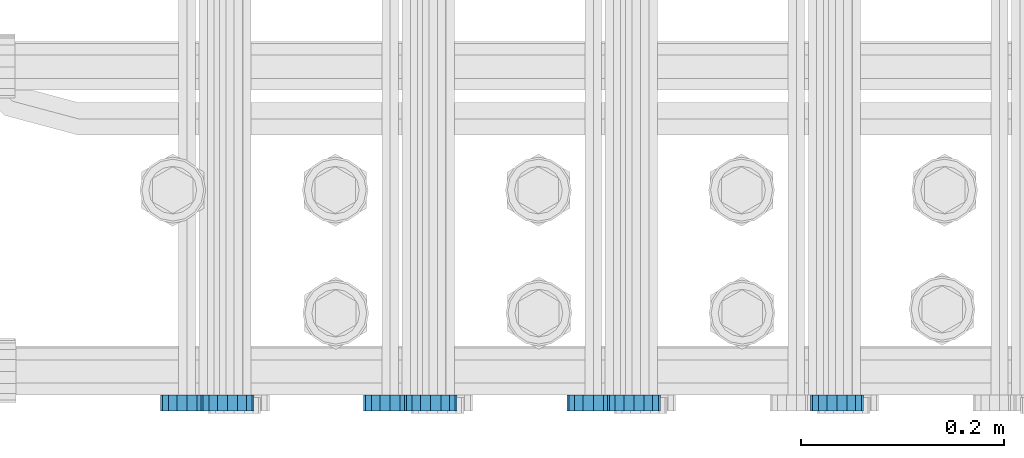
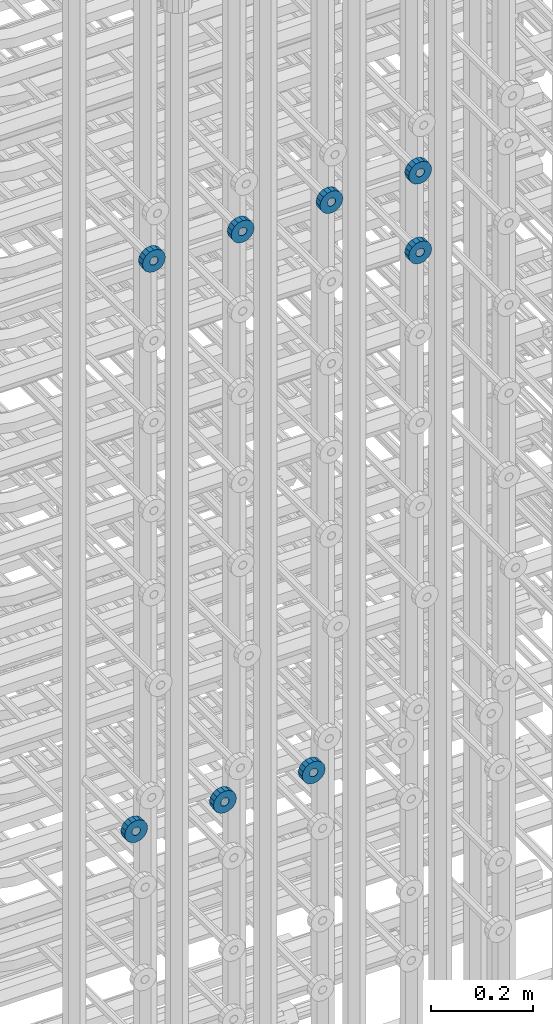
# One storey, part 116 of 177: 8 beams.
"""IFC2X3 building model written with IfcOpenShell, lengths in millimetres."""

from ifc_helpers import new_model, si_unit, frame, origin_with_axes, place, context, subcontext, project, spatial, faceted_brep, material, type_object, element, save


model = new_model("IFC2X3")

# Units and contexts
model_context_1 = context("Model", 3, precision=1e-05, world=origin_with_axes())
model_context_2 = context("Model", 3, precision=1e-05, world=origin_with_axes())
body_context = subcontext(model_context_2, "Body", "Model", "MODEL_VIEW")
ifc_project = project(units=[si_unit("LENGTHUNIT", "METRE", prefix="MILLI"), si_unit("AREAUNIT", "SQUARE_METRE"), si_unit("VOLUMEUNIT", "CUBIC_METRE"), si_unit("MASSUNIT", "GRAM", prefix="KILO"), si_unit("TIMEUNIT", "SECOND"), si_unit("PLANEANGLEUNIT", "RADIAN"), si_unit("SOLIDANGLEUNIT", "STERADIAN"), si_unit("THERMODYNAMICTEMPERATUREUNIT", "DEGREE_CELSIUS"), si_unit("LUMINOUSINTENSITYUNIT", "LUMEN")], contexts=[model_context_1])

# Site, building, storey
site_placement = place(None, origin_with_axes())
site = spatial("IfcSite", under=ifc_project, at=site_placement, CompositionType="ELEMENT")
building_placement = place(site_placement, origin_with_axes())
building = spatial("IfcBuilding", under=site, at=building_placement, Name="Undefined", CompositionType="ELEMENT")
storey_placement = place(building_placement, origin_with_axes())
storey = spatial("IfcBuildingStorey", under=building, at=storey_placement, Name="Undefined", CompositionType="ELEMENT", Elevation=0.0)

# Beams
ifc_material = material(Name="STEEL/Steel_Undefined")
beam_type = type_object("IfcBeamType", PredefinedType="NOTDEFINED")
beam_1_placement = place(storey_placement, frame((2030489.49847313, 6205075.98588033, 20799.986811442), z_axis=(0.0, 0.0, -1.0), x_axis=(0.0, -1.0, 0.0)))
element("IfcBeam", 1, at=beam_1_placement, inside=storey, type_object=beam_type, material=ifc_material, context=body_context, shape_type="Brep", body=[
    faceted_brep([(0.0, -9.5, 0.0), (0.0, -8.77685555908829, 3.63549260746731), (16.0, -8.77685555908829, 3.63549260746731), (16.0, -9.5, 0.0), (0.0, -6.71751442085952, 6.71751442127061), (16.0, -6.71751442085952, 6.71751442127061), (0.0, -3.63549260701984, 8.77685555885546), (16.0, -3.63549260701984, 8.77685555885546), (-2.02452244836415e-12, 0.0, 9.5), (16.0, 0.0, 9.5), (0.0, 3.63549260701984, 8.77685555885546), (16.0, 3.63549260701984, 8.77685555885546), (0.0, 6.71751442085952, 6.71751442127061), (16.0, 6.71751442085952, 6.71751442127061), (0.0, 8.77685555908829, 3.63549260746731), (16.0, 8.77685555908829, 3.63549260746731), (0.0, 9.5, 0.0), (16.0, 9.5, 0.0), (0.0, 8.77685555908829, -3.63549260746731), (16.0, 8.77685555908829, -3.63549260746731), (0.0, 6.71751442085952, -6.71751442127061), (16.0, 6.71751442085952, -6.71751442127061), (0.0, 3.63549260701984, -8.77685555885546), (16.0, 3.63549260701984, -8.77685555885546), (2.02452244836415e-12, -3.69149155687865e-15, -9.5), (16.0, 0.0, -9.5), (0.0, -3.63549260701984, -8.77685555885546), (16.0, -3.63549260701984, -8.77685555885546), (0.0, -6.71751442085952, -6.71751442127061), (16.0, -6.71751442085952, -6.71751442127061), (0.0, -8.77685555908829, -3.63549260746731), (16.0, -8.77685555908829, -3.63549260746731), (0.0, -26.0, 0.0), (0.0, -24.0208678450435, -9.94976924149159), (16.0, -24.0208678450435, -9.94976924149159), (16.0, -26.0, 0.0), (0.0, -18.3847763109952, -18.3847763108497), (16.0, -18.3847763109952, -18.3847763108497), (0.0, -9.94976924173534, -24.0208678452946), (16.0, -9.94976924173534, -24.0208678452946), (0.0, 0.0, -26.0), (16.0, 0.0, -26.0), (0.0, 9.94976924173534, -24.0208678452946), (16.0, 9.94976924173534, -24.0208678452946), (0.0, 18.3847763109952, -18.3847763108497), (16.0, 18.3847763109952, -18.3847763108497), (0.0, 24.0208678450435, -9.94976924149159), (16.0, 24.0208678450435, -9.94976924149159), (0.0, 26.0, 0.0), (16.0, 26.0, 0.0), (0.0, 24.0208678450435, 9.94976924149159), (16.0, 24.0208678450435, 9.94976924149159), (0.0, 18.3847763109952, 18.3847763108497), (16.0, 18.3847763109952, 18.3847763108497), (0.0, 9.94976924173534, 24.0208678452946), (16.0, 9.94976924173534, 24.0208678452946), (0.0, 0.0, 26.0), (16.0, 0.0, 26.0), (0.0, -9.94976924173534, 24.0208678452946), (16.0, -9.94976924173534, 24.0208678452946), (0.0, -18.3847763109952, 18.3847763108497), (16.0, -18.3847763109952, 18.3847763108497), (0.0, -24.0208678450435, 9.94976924149159), (16.0, -24.0208678450435, 9.94976924149159)], [[[0, 1, 2, 3]], [[1, 4, 5, 2]], [[4, 6, 7, 5]], [[6, 8, 9, 7]], [[8, 10, 11, 9]], [[10, 12, 13, 11]], [[12, 14, 15, 13]], [[14, 16, 17, 15]], [[16, 18, 19, 17]], [[18, 20, 21, 19]], [[20, 22, 23, 21]], [[22, 24, 25, 23]], [[24, 26, 27, 25]], [[26, 28, 29, 27]], [[28, 30, 31, 29]], [[30, 0, 3, 31]], [[32, 33, 34, 35]], [[33, 36, 37, 34]], [[36, 38, 39, 37]], [[38, 40, 41, 39]], [[40, 42, 43, 41]], [[42, 44, 45, 43]], [[44, 46, 47, 45]], [[46, 48, 49, 47]], [[48, 50, 51, 49]], [[50, 52, 53, 51]], [[52, 54, 55, 53]], [[54, 56, 57, 55]], [[56, 58, 59, 57]], [[58, 60, 61, 59]], [[60, 62, 63, 61]], [[62, 32, 35, 63]], [[37, 39, 41, 43, 45, 47, 49, 51, 53, 55, 57, 59, 61, 63, 35, 34], [5, 7, 9, 11, 13, 15, 17, 19, 21, 23, 25, 27, 29, 31, 3, 2]], [[62, 60, 58, 56, 54, 52, 50, 48, 46, 44, 42, 40, 38, 36, 33, 32], [30, 28, 26, 24, 22, 20, 18, 16, 14, 12, 10, 8, 6, 4, 1, 0]]]),
])
beam_2_placement = place(storey_placement, frame((2030289.49847313, 6205075.98588033, 20799.986811442), z_axis=(0.0, 0.0, -1.0), x_axis=(0.0, -1.0, 0.0)))
element("IfcBeam", 2, at=beam_2_placement, inside=storey, type_object=beam_type, material=ifc_material, context=body_context, shape_type="Brep", body=[
    faceted_brep([(0.0, -9.5, 0.0), (0.0, -8.77685555908829, 3.63549260746731), (16.0, -8.77685555908829, 3.63549260746731), (16.0, -9.5, 0.0), (0.0, -6.71751442085952, 6.71751442127061), (16.0, -6.71751442085952, 6.71751442127061), (0.0, -3.63549260701984, 8.77685555885546), (16.0, -3.63549260701984, 8.77685555885546), (-2.02452244836415e-12, 0.0, 9.5), (16.0, 0.0, 9.5), (0.0, 3.63549260701984, 8.77685555885546), (16.0, 3.63549260701984, 8.77685555885546), (0.0, 6.71751442085952, 6.71751442127061), (16.0, 6.71751442085952, 6.71751442127061), (0.0, 8.77685555908829, 3.63549260746731), (16.0, 8.77685555908829, 3.63549260746731), (0.0, 9.5, 0.0), (16.0, 9.5, 0.0), (0.0, 8.77685555908829, -3.63549260746731), (16.0, 8.77685555908829, -3.63549260746731), (0.0, 6.71751442085952, -6.71751442127061), (16.0, 6.71751442085952, -6.71751442127061), (0.0, 3.63549260701984, -8.77685555885546), (16.0, 3.63549260701984, -8.77685555885546), (2.02452244836415e-12, -3.69149155687865e-15, -9.5), (16.0, 0.0, -9.5), (0.0, -3.63549260701984, -8.77685555885546), (16.0, -3.63549260701984, -8.77685555885546), (0.0, -6.71751442085952, -6.71751442127061), (16.0, -6.71751442085952, -6.71751442127061), (0.0, -8.77685555908829, -3.63549260746731), (16.0, -8.77685555908829, -3.63549260746731), (0.0, -26.0, 0.0), (0.0, -24.0208678450435, -9.94976924149159), (16.0, -24.0208678450435, -9.94976924149159), (16.0, -26.0, 0.0), (0.0, -18.3847763109952, -18.3847763108497), (16.0, -18.3847763109952, -18.3847763108497), (0.0, -9.94976924173534, -24.0208678452946), (16.0, -9.94976924173534, -24.0208678452946), (0.0, 0.0, -26.0), (16.0, 0.0, -26.0), (0.0, 9.94976924173534, -24.0208678452946), (16.0, 9.94976924173534, -24.0208678452946), (0.0, 18.3847763109952, -18.3847763108497), (16.0, 18.3847763109952, -18.3847763108497), (0.0, 24.0208678450435, -9.94976924149159), (16.0, 24.0208678450435, -9.94976924149159), (0.0, 26.0, 0.0), (16.0, 26.0, 0.0), (0.0, 24.0208678450435, 9.94976924149159), (16.0, 24.0208678450435, 9.94976924149159), (0.0, 18.3847763109952, 18.3847763108497), (16.0, 18.3847763109952, 18.3847763108497), (0.0, 9.94976924173534, 24.0208678452946), (16.0, 9.94976924173534, 24.0208678452946), (0.0, 0.0, 26.0), (16.0, 0.0, 26.0), (0.0, -9.94976924173534, 24.0208678452946), (16.0, -9.94976924173534, 24.0208678452946), (0.0, -18.3847763109952, 18.3847763108497), (16.0, -18.3847763109952, 18.3847763108497), (0.0, -24.0208678450435, 9.94976924149159), (16.0, -24.0208678450435, 9.94976924149159)], [[[0, 1, 2, 3]], [[1, 4, 5, 2]], [[4, 6, 7, 5]], [[6, 8, 9, 7]], [[8, 10, 11, 9]], [[10, 12, 13, 11]], [[12, 14, 15, 13]], [[14, 16, 17, 15]], [[16, 18, 19, 17]], [[18, 20, 21, 19]], [[20, 22, 23, 21]], [[22, 24, 25, 23]], [[24, 26, 27, 25]], [[26, 28, 29, 27]], [[28, 30, 31, 29]], [[30, 0, 3, 31]], [[32, 33, 34, 35]], [[33, 36, 37, 34]], [[36, 38, 39, 37]], [[38, 40, 41, 39]], [[40, 42, 43, 41]], [[42, 44, 45, 43]], [[44, 46, 47, 45]], [[46, 48, 49, 47]], [[48, 50, 51, 49]], [[50, 52, 53, 51]], [[52, 54, 55, 53]], [[54, 56, 57, 55]], [[56, 58, 59, 57]], [[58, 60, 61, 59]], [[60, 62, 63, 61]], [[62, 32, 35, 63]], [[37, 39, 41, 43, 45, 47, 49, 51, 53, 55, 57, 59, 61, 63, 35, 34], [5, 7, 9, 11, 13, 15, 17, 19, 21, 23, 25, 27, 29, 31, 3, 2]], [[62, 60, 58, 56, 54, 52, 50, 48, 46, 44, 42, 40, 38, 36, 33, 32], [30, 28, 26, 24, 22, 20, 18, 16, 14, 12, 10, 8, 6, 4, 1, 0]]]),
])
beam_3_placement = place(storey_placement, frame((2030089.49847313, 6205075.98588033, 20799.986811442), z_axis=(0.0, 0.0, -1.0), x_axis=(0.0, -1.0, 0.0)))
element("IfcBeam", 3, at=beam_3_placement, inside=storey, type_object=beam_type, material=ifc_material, context=body_context, shape_type="Brep", body=[
    faceted_brep([(0.0, -9.5, 0.0), (0.0, -8.77685555908829, 3.63549260746731), (16.0, -8.77685555908829, 3.63549260746731), (16.0, -9.5, 0.0), (0.0, -6.71751442085952, 6.71751442127061), (16.0, -6.71751442085952, 6.71751442127061), (0.0, -3.63549260701984, 8.77685555885546), (16.0, -3.63549260701984, 8.77685555885546), (-2.02452244836415e-12, 0.0, 9.5), (16.0, 0.0, 9.5), (0.0, 3.63549260701984, 8.77685555885546), (16.0, 3.63549260701984, 8.77685555885546), (0.0, 6.71751442085952, 6.71751442127061), (16.0, 6.71751442085952, 6.71751442127061), (0.0, 8.77685555908829, 3.63549260746731), (16.0, 8.77685555908829, 3.63549260746731), (0.0, 9.5, 0.0), (16.0, 9.5, 0.0), (0.0, 8.77685555908829, -3.63549260746731), (16.0, 8.77685555908829, -3.63549260746731), (0.0, 6.71751442085952, -6.71751442127061), (16.0, 6.71751442085952, -6.71751442127061), (0.0, 3.63549260701984, -8.77685555885546), (16.0, 3.63549260701984, -8.77685555885546), (2.02452244836415e-12, -3.69149155687865e-15, -9.5), (16.0, 0.0, -9.5), (0.0, -3.63549260701984, -8.77685555885546), (16.0, -3.63549260701984, -8.77685555885546), (0.0, -6.71751442085952, -6.71751442127061), (16.0, -6.71751442085952, -6.71751442127061), (0.0, -8.77685555908829, -3.63549260746731), (16.0, -8.77685555908829, -3.63549260746731), (0.0, -26.0, 0.0), (0.0, -24.0208678450435, -9.94976924149159), (16.0, -24.0208678450435, -9.94976924149159), (16.0, -26.0, 0.0), (0.0, -18.3847763109952, -18.3847763108497), (16.0, -18.3847763109952, -18.3847763108497), (0.0, -9.94976924173534, -24.0208678452946), (16.0, -9.94976924173534, -24.0208678452946), (0.0, 0.0, -26.0), (16.0, 0.0, -26.0), (0.0, 9.94976924173534, -24.0208678452946), (16.0, 9.94976924173534, -24.0208678452946), (0.0, 18.3847763109952, -18.3847763108497), (16.0, 18.3847763109952, -18.3847763108497), (0.0, 24.0208678450435, -9.94976924149159), (16.0, 24.0208678450435, -9.94976924149159), (0.0, 26.0, 0.0), (16.0, 26.0, 0.0), (0.0, 24.0208678450435, 9.94976924149159), (16.0, 24.0208678450435, 9.94976924149159), (0.0, 18.3847763109952, 18.3847763108497), (16.0, 18.3847763109952, 18.3847763108497), (0.0, 9.94976924173534, 24.0208678452946), (16.0, 9.94976924173534, 24.0208678452946), (0.0, 0.0, 26.0), (16.0, 0.0, 26.0), (0.0, -9.94976924173534, 24.0208678452946), (16.0, -9.94976924173534, 24.0208678452946), (0.0, -18.3847763109952, 18.3847763108497), (16.0, -18.3847763109952, 18.3847763108497), (0.0, -24.0208678450435, 9.94976924149159), (16.0, -24.0208678450435, 9.94976924149159)], [[[0, 1, 2, 3]], [[1, 4, 5, 2]], [[4, 6, 7, 5]], [[6, 8, 9, 7]], [[8, 10, 11, 9]], [[10, 12, 13, 11]], [[12, 14, 15, 13]], [[14, 16, 17, 15]], [[16, 18, 19, 17]], [[18, 20, 21, 19]], [[20, 22, 23, 21]], [[22, 24, 25, 23]], [[24, 26, 27, 25]], [[26, 28, 29, 27]], [[28, 30, 31, 29]], [[30, 0, 3, 31]], [[32, 33, 34, 35]], [[33, 36, 37, 34]], [[36, 38, 39, 37]], [[38, 40, 41, 39]], [[40, 42, 43, 41]], [[42, 44, 45, 43]], [[44, 46, 47, 45]], [[46, 48, 49, 47]], [[48, 50, 51, 49]], [[50, 52, 53, 51]], [[52, 54, 55, 53]], [[54, 56, 57, 55]], [[56, 58, 59, 57]], [[58, 60, 61, 59]], [[60, 62, 63, 61]], [[62, 32, 35, 63]], [[37, 39, 41, 43, 45, 47, 49, 51, 53, 55, 57, 59, 61, 63, 35, 34], [5, 7, 9, 11, 13, 15, 17, 19, 21, 23, 25, 27, 29, 31, 3, 2]], [[62, 60, 58, 56, 54, 52, 50, 48, 46, 44, 42, 40, 38, 36, 33, 32], [30, 28, 26, 24, 22, 20, 18, 16, 14, 12, 10, 8, 6, 4, 1, 0]]]),
])
beam_4_placement = place(storey_placement, frame((2030729.49847313, 6205075.98588636, 22144.9868126721), z_axis=(0.0, 0.0, -1.0), x_axis=(0.0, -1.0, 0.0)))
element("IfcBeam", 4, at=beam_4_placement, inside=storey, type_object=beam_type, material=ifc_material, context=body_context, shape_type="Brep", body=[
    faceted_brep([(0.0, -9.5, 0.0), (0.0, -8.77685555908829, 3.63549260746731), (16.0, -8.77685555908829, 3.63549260746731), (16.0, -9.5, 0.0), (0.0, -6.71751442085952, 6.71751442127061), (16.0, -6.71751442085952, 6.71751442127061), (0.0, -3.63549260701984, 8.77685555885546), (16.0, -3.63549260701984, 8.77685555885546), (-2.02452244836415e-12, 0.0, 9.5), (16.0, 0.0, 9.5), (0.0, 3.63549260701984, 8.77685555885546), (16.0, 3.63549260701984, 8.77685555885546), (0.0, 6.71751442085952, 6.71751442127061), (16.0, 6.71751442085952, 6.71751442127061), (0.0, 8.77685555908829, 3.63549260746731), (16.0, 8.77685555908829, 3.63549260746731), (0.0, 9.5, 0.0), (16.0, 9.5, 0.0), (0.0, 8.77685555908829, -3.63549260746731), (16.0, 8.77685555908829, -3.63549260746731), (0.0, 6.71751442085952, -6.71751442127061), (16.0, 6.71751442085952, -6.71751442127061), (0.0, 3.63549260701984, -8.77685555885546), (16.0, 3.63549260701984, -8.77685555885546), (2.02452244836415e-12, -3.69149155687865e-15, -9.5), (16.0, 0.0, -9.5), (0.0, -3.63549260701984, -8.77685555885546), (16.0, -3.63549260701984, -8.77685555885546), (0.0, -6.71751442085952, -6.71751442127061), (16.0, -6.71751442085952, -6.71751442127061), (0.0, -8.77685555908829, -3.63549260746731), (16.0, -8.77685555908829, -3.63549260746731), (0.0, -26.0, 0.0), (0.0, -24.0208678450435, -9.94976924149159), (16.0, -24.0208678450435, -9.94976924149159), (16.0, -26.0, 0.0), (0.0, -18.3847763109952, -18.3847763108497), (16.0, -18.3847763109952, -18.3847763108497), (0.0, -9.94976924173534, -24.0208678452946), (16.0, -9.94976924173534, -24.0208678452946), (0.0, 0.0, -26.0), (16.0, 0.0, -26.0), (0.0, 9.94976924173534, -24.0208678452946), (16.0, 9.94976924173534, -24.0208678452946), (0.0, 18.3847763109952, -18.3847763108497), (16.0, 18.3847763109952, -18.3847763108497), (0.0, 24.0208678450435, -9.94976924149159), (16.0, 24.0208678450435, -9.94976924149159), (0.0, 26.0, 0.0), (16.0, 26.0, 0.0), (0.0, 24.0208678450435, 9.94976924149159), (16.0, 24.0208678450435, 9.94976924149159), (0.0, 18.3847763109952, 18.3847763108497), (16.0, 18.3847763109952, 18.3847763108497), (0.0, 9.94976924173534, 24.0208678452946), (16.0, 9.94976924173534, 24.0208678452946), (0.0, 0.0, 26.0), (16.0, 0.0, 26.0), (0.0, -9.94976924173534, 24.0208678452946), (16.0, -9.94976924173534, 24.0208678452946), (0.0, -18.3847763109952, 18.3847763108497), (16.0, -18.3847763109952, 18.3847763108497), (0.0, -24.0208678450435, 9.94976924149159), (16.0, -24.0208678450435, 9.94976924149159)], [[[0, 1, 2, 3]], [[1, 4, 5, 2]], [[4, 6, 7, 5]], [[6, 8, 9, 7]], [[8, 10, 11, 9]], [[10, 12, 13, 11]], [[12, 14, 15, 13]], [[14, 16, 17, 15]], [[16, 18, 19, 17]], [[18, 20, 21, 19]], [[20, 22, 23, 21]], [[22, 24, 25, 23]], [[24, 26, 27, 25]], [[26, 28, 29, 27]], [[28, 30, 31, 29]], [[30, 0, 3, 31]], [[32, 33, 34, 35]], [[33, 36, 37, 34]], [[36, 38, 39, 37]], [[38, 40, 41, 39]], [[40, 42, 43, 41]], [[42, 44, 45, 43]], [[44, 46, 47, 45]], [[46, 48, 49, 47]], [[48, 50, 51, 49]], [[50, 52, 53, 51]], [[52, 54, 55, 53]], [[54, 56, 57, 55]], [[56, 58, 59, 57]], [[58, 60, 61, 59]], [[60, 62, 63, 61]], [[62, 32, 35, 63]], [[37, 39, 41, 43, 45, 47, 49, 51, 53, 55, 57, 59, 61, 63, 35, 34], [5, 7, 9, 11, 13, 15, 17, 19, 21, 23, 25, 27, 29, 31, 3, 2]], [[62, 60, 58, 56, 54, 52, 50, 48, 46, 44, 42, 40, 38, 36, 33, 32], [30, 28, 26, 24, 22, 20, 18, 16, 14, 12, 10, 8, 6, 4, 1, 0]]]),
])
beam_5_placement = place(storey_placement, frame((2030529.49847313, 6205075.98588636, 22144.9868126721), z_axis=(0.0, 0.0, -1.0), x_axis=(0.0, -1.0, 0.0)))
element("IfcBeam", 5, at=beam_5_placement, inside=storey, type_object=beam_type, material=ifc_material, context=body_context, shape_type="Brep", body=[
    faceted_brep([(0.0, -9.5, 0.0), (0.0, -8.77685555908829, 3.63549260746731), (16.0, -8.77685555908829, 3.63549260746731), (16.0, -9.5, 0.0), (0.0, -6.71751442085952, 6.71751442127061), (16.0, -6.71751442085952, 6.71751442127061), (0.0, -3.63549260701984, 8.77685555885546), (16.0, -3.63549260701984, 8.77685555885546), (-2.02452244836415e-12, 0.0, 9.5), (16.0, 0.0, 9.5), (0.0, 3.63549260701984, 8.77685555885546), (16.0, 3.63549260701984, 8.77685555885546), (0.0, 6.71751442085952, 6.71751442127061), (16.0, 6.71751442085952, 6.71751442127061), (0.0, 8.77685555908829, 3.63549260746731), (16.0, 8.77685555908829, 3.63549260746731), (0.0, 9.5, 0.0), (16.0, 9.5, 0.0), (0.0, 8.77685555908829, -3.63549260746731), (16.0, 8.77685555908829, -3.63549260746731), (0.0, 6.71751442085952, -6.71751442127061), (16.0, 6.71751442085952, -6.71751442127061), (0.0, 3.63549260701984, -8.77685555885546), (16.0, 3.63549260701984, -8.77685555885546), (2.02452244836415e-12, -3.69149155687865e-15, -9.5), (16.0, 0.0, -9.5), (0.0, -3.63549260701984, -8.77685555885546), (16.0, -3.63549260701984, -8.77685555885546), (0.0, -6.71751442085952, -6.71751442127061), (16.0, -6.71751442085952, -6.71751442127061), (0.0, -8.77685555908829, -3.63549260746731), (16.0, -8.77685555908829, -3.63549260746731), (0.0, -26.0, 0.0), (0.0, -24.0208678450435, -9.94976924149159), (16.0, -24.0208678450435, -9.94976924149159), (16.0, -26.0, 0.0), (0.0, -18.3847763109952, -18.3847763108497), (16.0, -18.3847763109952, -18.3847763108497), (0.0, -9.94976924173534, -24.0208678452946), (16.0, -9.94976924173534, -24.0208678452946), (0.0, 0.0, -26.0), (16.0, 0.0, -26.0), (0.0, 9.94976924173534, -24.0208678452946), (16.0, 9.94976924173534, -24.0208678452946), (0.0, 18.3847763109952, -18.3847763108497), (16.0, 18.3847763109952, -18.3847763108497), (0.0, 24.0208678450435, -9.94976924149159), (16.0, 24.0208678450435, -9.94976924149159), (0.0, 26.0, 0.0), (16.0, 26.0, 0.0), (0.0, 24.0208678450435, 9.94976924149159), (16.0, 24.0208678450435, 9.94976924149159), (0.0, 18.3847763109952, 18.3847763108497), (16.0, 18.3847763109952, 18.3847763108497), (0.0, 9.94976924173534, 24.0208678452946), (16.0, 9.94976924173534, 24.0208678452946), (0.0, 0.0, 26.0), (16.0, 0.0, 26.0), (0.0, -9.94976924173534, 24.0208678452946), (16.0, -9.94976924173534, 24.0208678452946), (0.0, -18.3847763109952, 18.3847763108497), (16.0, -18.3847763109952, 18.3847763108497), (0.0, -24.0208678450435, 9.94976924149159), (16.0, -24.0208678450435, 9.94976924149159)], [[[0, 1, 2, 3]], [[1, 4, 5, 2]], [[4, 6, 7, 5]], [[6, 8, 9, 7]], [[8, 10, 11, 9]], [[10, 12, 13, 11]], [[12, 14, 15, 13]], [[14, 16, 17, 15]], [[16, 18, 19, 17]], [[18, 20, 21, 19]], [[20, 22, 23, 21]], [[22, 24, 25, 23]], [[24, 26, 27, 25]], [[26, 28, 29, 27]], [[28, 30, 31, 29]], [[30, 0, 3, 31]], [[32, 33, 34, 35]], [[33, 36, 37, 34]], [[36, 38, 39, 37]], [[38, 40, 41, 39]], [[40, 42, 43, 41]], [[42, 44, 45, 43]], [[44, 46, 47, 45]], [[46, 48, 49, 47]], [[48, 50, 51, 49]], [[50, 52, 53, 51]], [[52, 54, 55, 53]], [[54, 56, 57, 55]], [[56, 58, 59, 57]], [[58, 60, 61, 59]], [[60, 62, 63, 61]], [[62, 32, 35, 63]], [[37, 39, 41, 43, 45, 47, 49, 51, 53, 55, 57, 59, 61, 63, 35, 34], [5, 7, 9, 11, 13, 15, 17, 19, 21, 23, 25, 27, 29, 31, 3, 2]], [[62, 60, 58, 56, 54, 52, 50, 48, 46, 44, 42, 40, 38, 36, 33, 32], [30, 28, 26, 24, 22, 20, 18, 16, 14, 12, 10, 8, 6, 4, 1, 0]]]),
])
beam_6_placement = place(storey_placement, frame((2030329.49847313, 6205075.98588636, 22144.9868126721), z_axis=(0.0, 0.0, -1.0), x_axis=(0.0, -1.0, 0.0)))
element("IfcBeam", 6, at=beam_6_placement, inside=storey, type_object=beam_type, material=ifc_material, context=body_context, shape_type="Brep", body=[
    faceted_brep([(0.0, -9.5, 0.0), (0.0, -8.77685555908829, 3.63549260746731), (16.0, -8.77685555908829, 3.63549260746731), (16.0, -9.5, 0.0), (0.0, -6.71751442085952, 6.71751442127061), (16.0, -6.71751442085952, 6.71751442127061), (0.0, -3.63549260701984, 8.77685555885546), (16.0, -3.63549260701984, 8.77685555885546), (-2.02452244836415e-12, 0.0, 9.5), (16.0, 0.0, 9.5), (0.0, 3.63549260701984, 8.77685555885546), (16.0, 3.63549260701984, 8.77685555885546), (0.0, 6.71751442085952, 6.71751442127061), (16.0, 6.71751442085952, 6.71751442127061), (0.0, 8.77685555908829, 3.63549260746731), (16.0, 8.77685555908829, 3.63549260746731), (0.0, 9.5, 0.0), (16.0, 9.5, 0.0), (0.0, 8.77685555908829, -3.63549260746731), (16.0, 8.77685555908829, -3.63549260746731), (0.0, 6.71751442085952, -6.71751442127061), (16.0, 6.71751442085952, -6.71751442127061), (0.0, 3.63549260701984, -8.77685555885546), (16.0, 3.63549260701984, -8.77685555885546), (2.02452244836415e-12, -3.69149155687865e-15, -9.5), (16.0, 0.0, -9.5), (0.0, -3.63549260701984, -8.77685555885546), (16.0, -3.63549260701984, -8.77685555885546), (0.0, -6.71751442085952, -6.71751442127061), (16.0, -6.71751442085952, -6.71751442127061), (0.0, -8.77685555908829, -3.63549260746731), (16.0, -8.77685555908829, -3.63549260746731), (0.0, -26.0, 0.0), (0.0, -24.0208678450435, -9.94976924149159), (16.0, -24.0208678450435, -9.94976924149159), (16.0, -26.0, 0.0), (0.0, -18.3847763109952, -18.3847763108497), (16.0, -18.3847763109952, -18.3847763108497), (0.0, -9.94976924173534, -24.0208678452946), (16.0, -9.94976924173534, -24.0208678452946), (0.0, 0.0, -26.0), (16.0, 0.0, -26.0), (0.0, 9.94976924173534, -24.0208678452946), (16.0, 9.94976924173534, -24.0208678452946), (0.0, 18.3847763109952, -18.3847763108497), (16.0, 18.3847763109952, -18.3847763108497), (0.0, 24.0208678450435, -9.94976924149159), (16.0, 24.0208678450435, -9.94976924149159), (0.0, 26.0, 0.0), (16.0, 26.0, 0.0), (0.0, 24.0208678450435, 9.94976924149159), (16.0, 24.0208678450435, 9.94976924149159), (0.0, 18.3847763109952, 18.3847763108497), (16.0, 18.3847763109952, 18.3847763108497), (0.0, 9.94976924173534, 24.0208678452946), (16.0, 9.94976924173534, 24.0208678452946), (0.0, 0.0, 26.0), (16.0, 0.0, 26.0), (0.0, -9.94976924173534, 24.0208678452946), (16.0, -9.94976924173534, 24.0208678452946), (0.0, -18.3847763109952, 18.3847763108497), (16.0, -18.3847763109952, 18.3847763108497), (0.0, -24.0208678450435, 9.94976924149159), (16.0, -24.0208678450435, 9.94976924149159)], [[[0, 1, 2, 3]], [[1, 4, 5, 2]], [[4, 6, 7, 5]], [[6, 8, 9, 7]], [[8, 10, 11, 9]], [[10, 12, 13, 11]], [[12, 14, 15, 13]], [[14, 16, 17, 15]], [[16, 18, 19, 17]], [[18, 20, 21, 19]], [[20, 22, 23, 21]], [[22, 24, 25, 23]], [[24, 26, 27, 25]], [[26, 28, 29, 27]], [[28, 30, 31, 29]], [[30, 0, 3, 31]], [[32, 33, 34, 35]], [[33, 36, 37, 34]], [[36, 38, 39, 37]], [[38, 40, 41, 39]], [[40, 42, 43, 41]], [[42, 44, 45, 43]], [[44, 46, 47, 45]], [[46, 48, 49, 47]], [[48, 50, 51, 49]], [[50, 52, 53, 51]], [[52, 54, 55, 53]], [[54, 56, 57, 55]], [[56, 58, 59, 57]], [[58, 60, 61, 59]], [[60, 62, 63, 61]], [[62, 32, 35, 63]], [[37, 39, 41, 43, 45, 47, 49, 51, 53, 55, 57, 59, 61, 63, 35, 34], [5, 7, 9, 11, 13, 15, 17, 19, 21, 23, 25, 27, 29, 31, 3, 2]], [[62, 60, 58, 56, 54, 52, 50, 48, 46, 44, 42, 40, 38, 36, 33, 32], [30, 28, 26, 24, 22, 20, 18, 16, 14, 12, 10, 8, 6, 4, 1, 0]]]),
])
beam_7_placement = place(storey_placement, frame((2030129.49847313, 6205075.98588636, 22144.9868126721), z_axis=(0.0, 0.0, -1.0), x_axis=(0.0, -1.0, 0.0)))
element("IfcBeam", 7, at=beam_7_placement, inside=storey, type_object=beam_type, material=ifc_material, context=body_context, shape_type="Brep", body=[
    faceted_brep([(0.0, -9.5, 0.0), (0.0, -8.77685555908829, 3.63549260746731), (16.0, -8.77685555908829, 3.63549260746731), (16.0, -9.5, 0.0), (0.0, -6.71751442085952, 6.71751442127061), (16.0, -6.71751442085952, 6.71751442127061), (0.0, -3.63549260701984, 8.77685555885546), (16.0, -3.63549260701984, 8.77685555885546), (-2.02452244836415e-12, 0.0, 9.5), (16.0, 0.0, 9.5), (0.0, 3.63549260701984, 8.77685555885546), (16.0, 3.63549260701984, 8.77685555885546), (0.0, 6.71751442085952, 6.71751442127061), (16.0, 6.71751442085952, 6.71751442127061), (0.0, 8.77685555908829, 3.63549260746731), (16.0, 8.77685555908829, 3.63549260746731), (0.0, 9.5, 0.0), (16.0, 9.5, 0.0), (0.0, 8.77685555908829, -3.63549260746731), (16.0, 8.77685555908829, -3.63549260746731), (0.0, 6.71751442085952, -6.71751442127061), (16.0, 6.71751442085952, -6.71751442127061), (0.0, 3.63549260701984, -8.77685555885546), (16.0, 3.63549260701984, -8.77685555885546), (2.02452244836415e-12, -3.69149155687865e-15, -9.5), (16.0, 0.0, -9.5), (0.0, -3.63549260701984, -8.77685555885546), (16.0, -3.63549260701984, -8.77685555885546), (0.0, -6.71751442085952, -6.71751442127061), (16.0, -6.71751442085952, -6.71751442127061), (0.0, -8.77685555908829, -3.63549260746731), (16.0, -8.77685555908829, -3.63549260746731), (0.0, -26.0, 0.0), (0.0, -24.0208678450435, -9.94976924149159), (16.0, -24.0208678450435, -9.94976924149159), (16.0, -26.0, 0.0), (0.0, -18.3847763109952, -18.3847763108497), (16.0, -18.3847763109952, -18.3847763108497), (0.0, -9.94976924173534, -24.0208678452946), (16.0, -9.94976924173534, -24.0208678452946), (0.0, 0.0, -26.0), (16.0, 0.0, -26.0), (0.0, 9.94976924173534, -24.0208678452946), (16.0, 9.94976924173534, -24.0208678452946), (0.0, 18.3847763109952, -18.3847763108497), (16.0, 18.3847763109952, -18.3847763108497), (0.0, 24.0208678450435, -9.94976924149159), (16.0, 24.0208678450435, -9.94976924149159), (0.0, 26.0, 0.0), (16.0, 26.0, 0.0), (0.0, 24.0208678450435, 9.94976924149159), (16.0, 24.0208678450435, 9.94976924149159), (0.0, 18.3847763109952, 18.3847763108497), (16.0, 18.3847763109952, 18.3847763108497), (0.0, 9.94976924173534, 24.0208678452946), (16.0, 9.94976924173534, 24.0208678452946), (0.0, 0.0, 26.0), (16.0, 0.0, 26.0), (0.0, -9.94976924173534, 24.0208678452946), (16.0, -9.94976924173534, 24.0208678452946), (0.0, -18.3847763109952, 18.3847763108497), (16.0, -18.3847763109952, 18.3847763108497), (0.0, -24.0208678450435, 9.94976924149159), (16.0, -24.0208678450435, 9.94976924149159)], [[[0, 1, 2, 3]], [[1, 4, 5, 2]], [[4, 6, 7, 5]], [[6, 8, 9, 7]], [[8, 10, 11, 9]], [[10, 12, 13, 11]], [[12, 14, 15, 13]], [[14, 16, 17, 15]], [[16, 18, 19, 17]], [[18, 20, 21, 19]], [[20, 22, 23, 21]], [[22, 24, 25, 23]], [[24, 26, 27, 25]], [[26, 28, 29, 27]], [[28, 30, 31, 29]], [[30, 0, 3, 31]], [[32, 33, 34, 35]], [[33, 36, 37, 34]], [[36, 38, 39, 37]], [[38, 40, 41, 39]], [[40, 42, 43, 41]], [[42, 44, 45, 43]], [[44, 46, 47, 45]], [[46, 48, 49, 47]], [[48, 50, 51, 49]], [[50, 52, 53, 51]], [[52, 54, 55, 53]], [[54, 56, 57, 55]], [[56, 58, 59, 57]], [[58, 60, 61, 59]], [[60, 62, 63, 61]], [[62, 32, 35, 63]], [[37, 39, 41, 43, 45, 47, 49, 51, 53, 55, 57, 59, 61, 63, 35, 34], [5, 7, 9, 11, 13, 15, 17, 19, 21, 23, 25, 27, 29, 31, 3, 2]], [[62, 60, 58, 56, 54, 52, 50, 48, 46, 44, 42, 40, 38, 36, 33, 32], [30, 28, 26, 24, 22, 20, 18, 16, 14, 12, 10, 8, 6, 4, 1, 0]]]),
])
beam_8_placement = place(storey_placement, frame((2030729.49847313, 6205075.98588032, 21954.9868114202), z_axis=(0.0, 0.0, -1.0), x_axis=(0.0, -1.0, 0.0)))
element("IfcBeam", 8, at=beam_8_placement, inside=storey, type_object=beam_type, material=ifc_material, context=body_context, shape_type="Brep", body=[
    faceted_brep([(0.0, -9.5, 0.0), (0.0, -8.77685555908829, 3.63549260746731), (16.0, -8.77685555908829, 3.63549260746731), (16.0, -9.5, 0.0), (0.0, -6.71751442085952, 6.71751442127061), (16.0, -6.71751442085952, 6.71751442127061), (0.0, -3.63549260701984, 8.77685555885546), (16.0, -3.63549260701984, 8.77685555885546), (-2.02452244836415e-12, 0.0, 9.5), (16.0, 0.0, 9.5), (0.0, 3.63549260701984, 8.77685555885546), (16.0, 3.63549260701984, 8.77685555885546), (0.0, 6.71751442085952, 6.71751442127061), (16.0, 6.71751442085952, 6.71751442127061), (0.0, 8.77685555908829, 3.63549260746731), (16.0, 8.77685555908829, 3.63549260746731), (0.0, 9.5, 0.0), (16.0, 9.5, 0.0), (0.0, 8.77685555908829, -3.63549260746731), (16.0, 8.77685555908829, -3.63549260746731), (0.0, 6.71751442085952, -6.71751442127061), (16.0, 6.71751442085952, -6.71751442127061), (0.0, 3.63549260701984, -8.77685555885546), (16.0, 3.63549260701984, -8.77685555885546), (2.02452244836415e-12, -3.69149155687865e-15, -9.5), (16.0, 0.0, -9.5), (0.0, -3.63549260701984, -8.77685555885546), (16.0, -3.63549260701984, -8.77685555885546), (0.0, -6.71751442085952, -6.71751442127061), (16.0, -6.71751442085952, -6.71751442127061), (0.0, -8.77685555908829, -3.63549260746731), (16.0, -8.77685555908829, -3.63549260746731), (0.0, -26.0, 0.0), (0.0, -24.0208678450435, -9.94976924149159), (16.0, -24.0208678450435, -9.94976924149159), (16.0, -26.0, 0.0), (0.0, -18.3847763109952, -18.3847763108497), (16.0, -18.3847763109952, -18.3847763108497), (0.0, -9.94976924173534, -24.0208678452946), (16.0, -9.94976924173534, -24.0208678452946), (0.0, 0.0, -26.0), (16.0, 0.0, -26.0), (0.0, 9.94976924173534, -24.0208678452946), (16.0, 9.94976924173534, -24.0208678452946), (0.0, 18.3847763109952, -18.3847763108497), (16.0, 18.3847763109952, -18.3847763108497), (0.0, 24.0208678450435, -9.94976924149159), (16.0, 24.0208678450435, -9.94976924149159), (0.0, 26.0, 0.0), (16.0, 26.0, 0.0), (0.0, 24.0208678450435, 9.94976924149159), (16.0, 24.0208678450435, 9.94976924149159), (0.0, 18.3847763109952, 18.3847763108497), (16.0, 18.3847763109952, 18.3847763108497), (0.0, 9.94976924173534, 24.0208678452946), (16.0, 9.94976924173534, 24.0208678452946), (0.0, 0.0, 26.0), (16.0, 0.0, 26.0), (0.0, -9.94976924173534, 24.0208678452946), (16.0, -9.94976924173534, 24.0208678452946), (0.0, -18.3847763109952, 18.3847763108497), (16.0, -18.3847763109952, 18.3847763108497), (0.0, -24.0208678450435, 9.94976924149159), (16.0, -24.0208678450435, 9.94976924149159)], [[[0, 1, 2, 3]], [[1, 4, 5, 2]], [[4, 6, 7, 5]], [[6, 8, 9, 7]], [[8, 10, 11, 9]], [[10, 12, 13, 11]], [[12, 14, 15, 13]], [[14, 16, 17, 15]], [[16, 18, 19, 17]], [[18, 20, 21, 19]], [[20, 22, 23, 21]], [[22, 24, 25, 23]], [[24, 26, 27, 25]], [[26, 28, 29, 27]], [[28, 30, 31, 29]], [[30, 0, 3, 31]], [[32, 33, 34, 35]], [[33, 36, 37, 34]], [[36, 38, 39, 37]], [[38, 40, 41, 39]], [[40, 42, 43, 41]], [[42, 44, 45, 43]], [[44, 46, 47, 45]], [[46, 48, 49, 47]], [[48, 50, 51, 49]], [[50, 52, 53, 51]], [[52, 54, 55, 53]], [[54, 56, 57, 55]], [[56, 58, 59, 57]], [[58, 60, 61, 59]], [[60, 62, 63, 61]], [[62, 32, 35, 63]], [[37, 39, 41, 43, 45, 47, 49, 51, 53, 55, 57, 59, 61, 63, 35, 34], [5, 7, 9, 11, 13, 15, 17, 19, 21, 23, 25, 27, 29, 31, 3, 2]], [[62, 60, 58, 56, 54, 52, 50, 48, 46, 44, 42, 40, 38, 36, 33, 32], [30, 28, 26, 24, 22, 20, 18, 16, 14, 12, 10, 8, 6, 4, 1, 0]]]),
])

save(model, "model.ifc")
